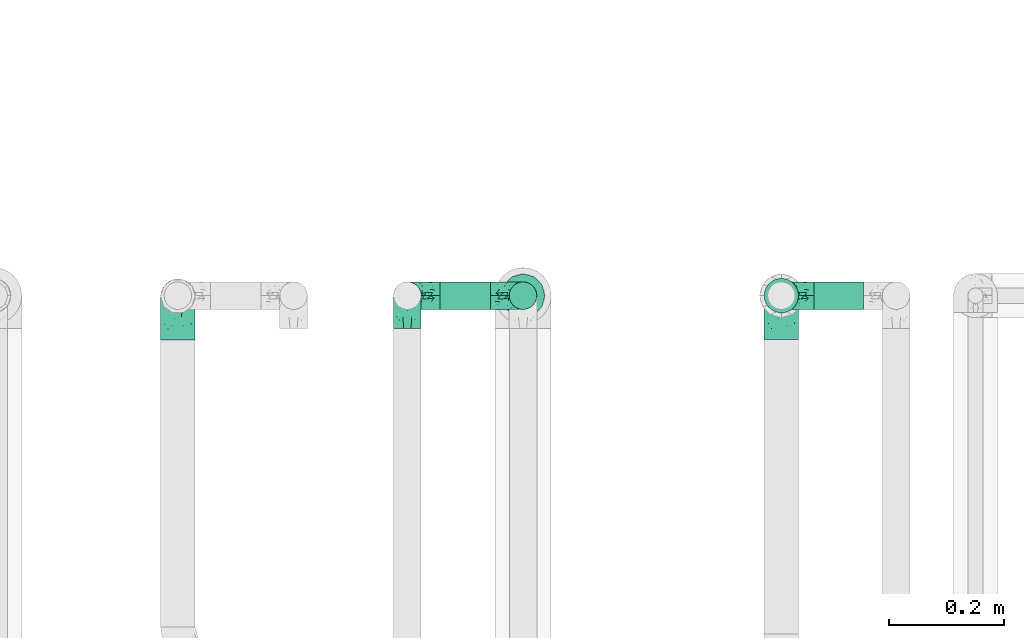
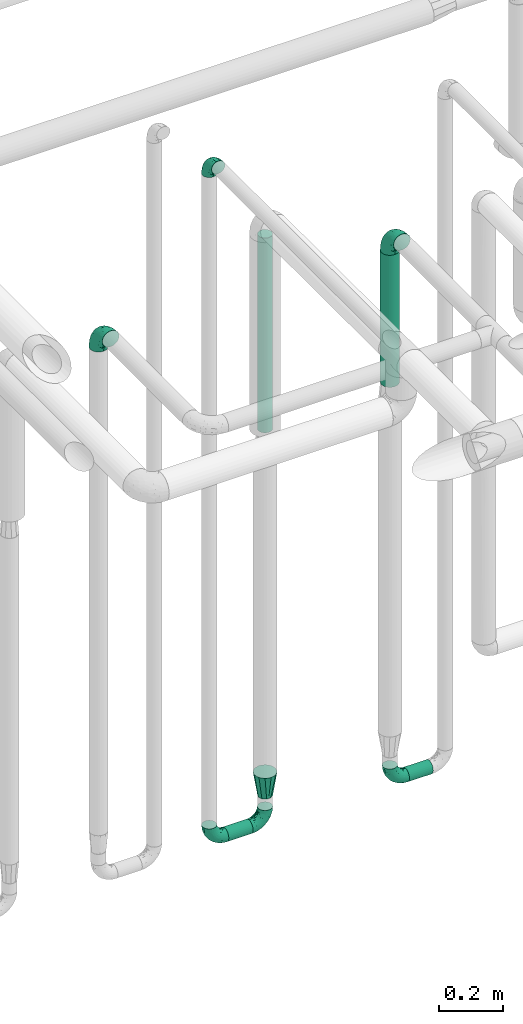
# One storey, part 698 of 827: 7 flow fittings, 4 flow segments.
"""IFC2X3 building model written with IfcOpenShell, lengths in millimetres."""

from ifc_helpers import new_model, entity, si_unit, converted_unit, derived_unit, direction, frame, origin, origin_2d_with_axis, place, context, subcontext, project, spatial, circle, extrude, faceted_brep, source, transform, mapped, material, type_object, type_shapes, element, save


model = new_model("IFC2X3")

# Units and contexts
model_context = context("Model", 3, precision=0.01, world=origin(), true_north=direction((6.12303176911189e-17, 1.0)))
body_context = subcontext(model_context, "Body", "Model", "MODEL_VIEW")
ifc_project = project(units=[si_unit("LENGTHUNIT", "METRE", prefix="MILLI"), si_unit("AREAUNIT", "SQUARE_METRE"), si_unit("VOLUMEUNIT", "CUBIC_METRE"), converted_unit("PLANEANGLEUNIT", "DEGREE", entity("IfcRatioMeasure", 0.0174532925199433), si_unit("PLANEANGLEUNIT", "RADIAN"), dimensions=[0, 0, 0, 0, 0, 0, 0]), si_unit("MASSUNIT", "GRAM", prefix="KILO"), derived_unit("MASSDENSITYUNIT", [(si_unit("MASSUNIT", "GRAM", prefix="KILO"), 1), (si_unit("LENGTHUNIT", "METRE"), -3)]), derived_unit("MOMENTOFINERTIAUNIT", [(si_unit("LENGTHUNIT", "METRE"), 4)]), si_unit("TIMEUNIT", "SECOND"), si_unit("FREQUENCYUNIT", "HERTZ"), si_unit("THERMODYNAMICTEMPERATUREUNIT", "DEGREE_CELSIUS"), derived_unit("THERMALTRANSMITTANCEUNIT", [(si_unit("MASSUNIT", "GRAM", prefix="KILO"), 1), (si_unit("THERMODYNAMICTEMPERATUREUNIT", "KELVIN"), -1), (si_unit("TIMEUNIT", "SECOND"), -3)]), derived_unit("VOLUMETRICFLOWRATEUNIT", [(si_unit("LENGTHUNIT", "METRE"), 3), (si_unit("TIMEUNIT", "SECOND"), -1)]), derived_unit("MASSFLOWRATEUNIT", [(si_unit("MASSUNIT", "GRAM", prefix="KILO"), 1), (si_unit("TIMEUNIT", "SECOND"), -1)]), derived_unit("ROTATIONALFREQUENCYUNIT", [(si_unit("TIMEUNIT", "SECOND"), -1)]), si_unit("ELECTRICCURRENTUNIT", "AMPERE"), si_unit("ELECTRICVOLTAGEUNIT", "VOLT"), si_unit("POWERUNIT", "WATT"), si_unit("FORCEUNIT", "NEWTON", prefix="KILO"), si_unit("ILLUMINANCEUNIT", "LUX"), si_unit("LUMINOUSFLUXUNIT", "LUMEN"), si_unit("LUMINOUSINTENSITYUNIT", "CANDELA"), derived_unit("USERDEFINED", [(si_unit("MASSUNIT", "GRAM", prefix="KILO"), -1), (si_unit("LENGTHUNIT", "METRE"), -2), (si_unit("TIMEUNIT", "SECOND"), 3), (si_unit("LUMINOUSFLUXUNIT", "LUMEN"), 1)]), derived_unit("LINEARVELOCITYUNIT", [(si_unit("LENGTHUNIT", "METRE"), 1), (si_unit("TIMEUNIT", "SECOND"), -1)]), si_unit("PRESSUREUNIT", "PASCAL"), derived_unit("USERDEFINED", [(si_unit("LENGTHUNIT", "METRE"), -2), (si_unit("MASSUNIT", "GRAM", prefix="KILO"), 1), (si_unit("TIMEUNIT", "SECOND"), -2)]), derived_unit("LINEARFORCEUNIT", [(si_unit("MASSUNIT", "GRAM", prefix="KILO"), 1), (si_unit("LENGTHUNIT", "METRE"), 1), (si_unit("TIMEUNIT", "SECOND"), -2), (si_unit("LENGTHUNIT", "METRE"), -1)]), derived_unit("PLANARFORCEUNIT", [(si_unit("MASSUNIT", "GRAM", prefix="KILO"), 1), (si_unit("LENGTHUNIT", "METRE"), 1), (si_unit("TIMEUNIT", "SECOND"), -2), (si_unit("LENGTHUNIT", "METRE"), -2)])], contexts=[model_context])

# Site, building, storey
site_placement = place(None, origin())
site = spatial("IfcSite", under=ifc_project, at=site_placement, CompositionType="ELEMENT")
building_placement = place(site_placement, origin())
building = spatial("IfcBuilding", under=site, at=building_placement, CompositionType="ELEMENT")
storey_placement = place(building_placement, frame((0.0, 0.0, 28200.0)))
storey = spatial("IfcBuildingStorey", under=building, at=storey_placement, Name="08", CompositionType="ELEMENT", Elevation=28200.0)

# Flow segments
pipe_segment_type = type_object("IfcPipeSegmentType", PredefinedType="NOTDEFINED")
flow_segment_1_placement = place(storey_placement, frame((53539.81, 17468.4, 1918.17)))
element("IfcFlowSegment", 1, at=flow_segment_1_placement, inside=storey, type_object=pipe_segment_type, context=body_context, shape_type="SweptSolid", body=[
    extrude(circle(Radius=30.0, at=origin_2d_with_axis()), frame((31.6, 31.6, 0.0)), (0.0, 0.0, 1.0), 504.000000000011),
])
flow_segment_2_placement = place(storey_placement, frame((52976.38, 17474.4, 374.4)))
element("IfcFlowSegment", 2, at=flow_segment_2_placement, inside=storey, type_object=pipe_segment_type, context=body_context, shape_type="SweptSolid", body=[
    extrude(circle(Radius=24.0, at=origin_2d_with_axis()), frame((0.0, 25.6, 25.6), z_axis=(1.0, 0.0, 0.0), x_axis=(0.0, 1.0, 0.0)), (0.0, 0.0, 1.0), 87.6742700000116),
])
flow_segment_3_placement = place(storey_placement, frame((53095.46, 17474.4, 1898.17)))
element("IfcFlowSegment", 3, at=flow_segment_3_placement, inside=storey, type_object=pipe_segment_type, context=body_context, shape_type="SweptSolid", body=[
    extrude(circle(Radius=24.0, at=origin_2d_with_axis()), frame((25.6, 25.6, 0.0)), (0.0, 0.0, 1.0), 743.078196918212),
])
flow_segment_4_placement = place(storey_placement, frame((53628.41, 17474.4, 374.4)))
element("IfcFlowSegment", 4, at=flow_segment_4_placement, inside=storey, type_object=pipe_segment_type, context=body_context, shape_type="SweptSolid", body=[
    extrude(circle(Radius=24.0, at=origin_2d_with_axis()), frame((0.0, 25.6, 25.6), z_axis=(1.0, 0.0, 0.0), x_axis=(0.0, 1.0, 0.0)), (0.0, 0.0, 1.0), 86.0000000000238),
])

# Flow fittings
ifc_material = material()
pipe_fitting_type_1 = type_object("IfcPipeFittingType", Name="ADSK_1", PredefinedType="NOTDEFINED", material=ifc_material)
shared_shape_1 = source(origin(), body_context, "Body", "Brep", [
    faceted_brep([(-57.0, 12.07, -20.91), (-57.0, 6.25, -23.33), (-57.0, 0.0, -24.15), (-57.0, -6.25, -23.33), (-57.0, -12.08, -20.91), (-57.0, -17.08, -17.08), (-57.0, -20.91, -12.08), (-57.0, -23.33, -6.25), (-57.0, -24.15, 0.0), (-57.0, -23.33, 6.25), (-57.0, -20.91, 12.07), (-57.0, -17.08, 17.08), (-57.0, -12.08, 20.91), (-57.0, -6.25, 23.33), (-57.0, 0.0, 24.15), (-57.0, 6.25, 23.33), (-57.0, 12.07, 20.91), (-57.0, 17.08, 17.08), (-57.0, 20.91, 12.07), (-57.0, 23.33, 6.25), (-57.0, 24.15, 0.0), (-57.0, 23.33, -6.25), (-57.0, 20.91, -12.08), (-57.0, 17.08, -17.08), (0.0, 57.0, -24.15), (-6.25, 57.0, -23.33), (-12.07, 57.0, -20.91), (-17.08, 57.0, -17.08), (-20.91, 57.0, -12.08), (-23.33, 57.0, -6.25), (-24.15, 57.0, 0.0), (-23.33, 57.0, 6.25), (-20.91, 57.0, 12.07), (-17.08, 57.0, 17.08), (-12.07, 57.0, 20.91), (-6.25, 57.0, 23.33), (0.0, 57.0, 24.15), (6.25, 57.0, 23.33), (12.08, 57.0, 20.91), (17.08, 57.0, 17.08), (20.91, 57.0, 12.07), (23.33, 57.0, 6.25), (24.15, 57.0, 0.0), (23.33, 57.0, -6.25), (20.91, 57.0, -12.08), (17.08, 57.0, -17.08), (12.08, 57.0, -20.91), (6.25, 57.0, -23.33), (14.9, 21.14, 6.17), (13.61, 24.64, 12.48), (6.23, 8.95, 8.98), (-41.47, -21.06, 0.0), (-41.92, -18.38, 13.72), (-24.64, -13.61, 12.48), (-37.37, -13.24, 18.15), (-6.8, -4.93, 8.18), (-21.76, -15.19, 6.22), (-12.78, -9.18, 0.0), (-37.73, -20.51, 7.75), (-7.38, 7.38, 20.24), (-23.37, -4.26, 20.42), (-11.9, -3.19, 15.86), (-42.14, -8.7, 21.82), (13.24, 37.37, 18.15), (9.33, 23.53, 16.85), (4.26, 23.37, 20.42), (2.77, 10.92, 15.55), (-29.46, 0.91, 23.52), (-44.13, 20.56, 15.69), (-39.25, 26.33, 10.88), (-49.02, 22.92, 9.96), (-34.58, 23.87, 17.15), (-15.8, 6.8, 22.81), (-8.67, 20.47, 23.88), (-18.12, 12.9, 24.08), (-48.29, 14.92, 19.65), (-44.06, -2.85, 23.78), (-9.23, 48.95, 22.58), (-3.78, 42.74, 24.07), (-40.34, 4.26, 24.09), (-44.02, 26.14, 5.46), (-44.04, 9.88, 22.74), (-4.95, 16.87, 22.52), (-2.75, 1.43, 12.5), (-25.48, 40.98, 10.71), (20.51, 37.73, 7.75), (18.38, 41.92, 13.72), (8.7, 42.14, 21.82), (-25.95, -17.97, 0.0), (2.85, 44.06, 23.78), (21.06, 41.47, 0.0), (17.97, 25.95, 0.0), (-24.04, -9.27, 17.13), (-33.26, 33.26, 5.86), (-28.55, 40.57, 0.0), (-40.57, 28.55, 0.0), (-25.29, 47.19, 4.06), (-27.01, 31.1, 16.77), (-15.7, 43.95, 19.9), (-20.27, 45.22, 15.61), (-30.53, 31.98, 12.64), (-11.28, 38.33, 22.92), (-9.97, 27.88, 24.09), (-20.15, 30.26, 21.25), (-31.25, 11.75, 23.64), (-28.75, 7.23, 24.15), (-29.53, 18.06, 22.27), (-28.44, 24.21, 20.02), (-37.55, 17.7, 20.26), (-15.88, 29.25, 22.99), (-20.82, 20.82, 23.44), (-0.91, 29.46, 23.52), (-13.5, -7.67, 12.04), (1.49, 1.56, 5.16), (8.86, 10.35, 4.59), (0.38, -0.38, 0.0), (9.18, 12.78, 0.0), (-37.37, -13.24, -18.15), (8.86, 10.35, -4.59), (-45.22, 20.27, -15.61), (-43.95, 15.7, -19.9), (-38.33, 11.28, -22.92), (-48.95, 9.23, -22.58), (-47.19, 25.29, -4.06), (-33.26, 33.26, -5.86), (18.38, 41.92, -13.72), (-30.26, 20.15, -21.25), (2.85, 44.06, -23.78), (-4.26, 40.34, -24.09), (-40.98, 25.48, -10.71), (-41.92, -18.38, -13.72), (9.25, 23.5, -16.92), (4.26, 23.37, -20.42), (13.24, 37.37, -18.15), (-37.73, -20.51, -7.75), (-11.75, 31.25, -23.64), (-7.23, 28.75, -24.15), (-12.9, 18.12, -24.08), (8.7, 42.14, -21.82), (-44.06, -2.85, -23.78), (-6.8, 15.8, -22.81), (-20.47, 8.67, -23.88), (-24.64, -13.61, -12.48), (-42.74, 3.78, -24.07), (-18.06, 29.53, -22.27), (-24.21, 28.44, -20.02), (-27.88, 9.97, -24.09), (-31.1, 27.01, -16.77), (-26.14, 44.02, -5.46), (14.9, 21.14, -6.17), (20.51, 37.73, -7.75), (-9.88, 44.04, -22.74), (-20.56, 44.13, -15.69), (-21.76, -15.19, -6.22), (-13.5, -7.67, -12.04), (-24.14, -9.76, -16.74), (-11.9, -3.19, -15.86), (-14.92, 48.29, -19.65), (-23.37, -4.26, -20.42), (-0.91, 29.46, -23.52), (-26.33, 39.25, -10.88), (-23.87, 34.58, -17.15), (-42.14, -8.7, -21.82), (-22.92, 49.02, -9.96), (13.61, 24.64, -12.48), (-31.98, 30.53, -12.64), (-16.87, 4.95, -22.52), (-17.7, 37.55, -20.26), (-29.25, 15.88, -22.99), (-20.82, 20.82, -23.44), (-29.46, 0.91, -23.52), (-7.38, 7.38, -20.24), (2.77, 10.92, -15.55), (6.23, 8.95, -8.98), (-6.8, -4.93, -8.18), (-2.81, 1.41, -12.54), (1.49, 1.56, -5.16)], [[[0, 1, 2, 3, 4, 5, 6, 7, 8, 9, 10, 11, 12, 13, 14, 15, 16, 17, 18, 19, 20, 21, 22, 23]], [[24, 25, 26, 27, 28, 29, 30, 31, 32, 33, 34, 35, 36, 37, 38, 39, 40, 41, 42, 43, 44, 45, 46, 47]], [[48, 49, 50]], [[9, 8, 51]], [[52, 53, 54]], [[55, 56, 57]], [[10, 58, 52]], [[9, 58, 10]], [[59, 60, 61]], [[54, 12, 11]], [[54, 62, 12]], [[63, 39, 38]], [[64, 65, 66]], [[62, 60, 67]], [[68, 69, 70]], [[71, 69, 68]], [[72, 73, 74]], [[16, 75, 17]], [[13, 76, 14]], [[35, 77, 78]], [[14, 79, 15]], [[17, 68, 18]], [[14, 76, 79]], [[20, 19, 80]], [[70, 19, 18]], [[81, 15, 79]], [[15, 81, 16]], [[73, 72, 82]], [[66, 83, 50]], [[32, 31, 84]], [[85, 86, 49]], [[63, 87, 65]], [[56, 58, 88]], [[36, 89, 37]], [[85, 41, 40]], [[36, 35, 78]], [[90, 41, 85]], [[40, 39, 86]], [[12, 62, 13]], [[86, 85, 40]], [[48, 85, 49]], [[85, 91, 90]], [[87, 38, 37]], [[92, 60, 54]], [[80, 69, 93]], [[93, 94, 95]], [[10, 52, 11]], [[94, 96, 30]], [[97, 98, 99]], [[80, 93, 95]], [[100, 97, 84]], [[99, 98, 33]], [[101, 102, 78]], [[103, 101, 98]], [[96, 31, 30]], [[77, 98, 101]], [[77, 35, 34]], [[34, 33, 98]], [[9, 51, 58]], [[87, 63, 38]], [[104, 105, 74]], [[106, 103, 107]], [[106, 81, 104]], [[75, 68, 17]], [[108, 107, 71]], [[33, 32, 99]], [[109, 103, 110]], [[101, 109, 102]], [[89, 78, 111]], [[53, 52, 58]], [[54, 11, 52]], [[60, 62, 54]], [[88, 58, 51]], [[76, 62, 67]], [[53, 112, 92]], [[60, 59, 72]], [[39, 63, 86]], [[49, 86, 63]], [[89, 87, 37]], [[42, 41, 90]], [[111, 82, 65]], [[111, 65, 87]], [[65, 59, 66]], [[104, 81, 79]], [[75, 81, 108]], [[32, 84, 99]], [[97, 99, 84]], [[98, 97, 103]], [[106, 107, 108]], [[74, 102, 110]], [[111, 78, 102]], [[74, 110, 104]], [[74, 67, 72]], [[61, 92, 112]], [[66, 59, 61]], [[56, 53, 58]], [[66, 50, 49]], [[61, 112, 83]], [[66, 49, 64]], [[78, 89, 36]], [[87, 89, 111]], [[62, 76, 13]], [[79, 76, 67]], [[100, 93, 69]], [[96, 93, 84]], [[55, 113, 50]], [[113, 114, 50]], [[104, 79, 105]], [[106, 104, 110]], [[20, 80, 95]], [[85, 48, 91]], [[115, 114, 113]], [[116, 91, 48]], [[70, 80, 19]], [[93, 96, 94]], [[84, 31, 96]], [[103, 106, 110]], [[81, 106, 108]], [[103, 97, 107]], [[71, 107, 97]], [[71, 97, 100]], [[108, 71, 68]], [[79, 67, 105]], [[67, 74, 105]], [[115, 113, 57]], [[112, 56, 55]], [[56, 88, 57]], [[60, 72, 67]], [[82, 72, 59]], [[65, 82, 59]], [[82, 111, 73]], [[111, 102, 73]], [[102, 74, 73]], [[81, 75, 16]], [[68, 75, 108]], [[68, 70, 18]], [[80, 70, 69]], [[98, 77, 34]], [[78, 77, 101]], [[93, 100, 84]], [[71, 100, 69]], [[102, 109, 110]], [[101, 103, 109]], [[53, 92, 54]], [[61, 60, 92]], [[56, 112, 53]], [[83, 112, 55]], [[50, 83, 55]], [[61, 83, 66]], [[49, 63, 64]], [[65, 64, 63]], [[57, 113, 55]], [[114, 115, 116]], [[116, 48, 114]], [[48, 50, 114]], [[117, 5, 4]], [[116, 115, 118]], [[119, 120, 23]], [[121, 122, 120]], [[95, 123, 20]], [[0, 23, 120]], [[124, 95, 94]], [[125, 45, 44]], [[121, 120, 126]], [[24, 127, 128]], [[22, 21, 129]], [[0, 122, 1]], [[5, 117, 130]], [[131, 132, 133]], [[134, 88, 51]], [[135, 136, 137]], [[6, 5, 130]], [[46, 138, 47]], [[139, 3, 2]], [[140, 141, 137]], [[6, 134, 7]], [[134, 130, 142]], [[143, 2, 1]], [[144, 126, 145]], [[121, 146, 143]], [[147, 120, 119]], [[94, 148, 124]], [[149, 150, 91]], [[30, 29, 148]], [[151, 25, 128]], [[27, 152, 28]], [[134, 153, 88]], [[154, 155, 156]], [[27, 26, 157]], [[151, 26, 25]], [[155, 158, 156]], [[24, 47, 127]], [[1, 122, 143]], [[138, 132, 159]], [[160, 152, 161]], [[24, 128, 25]], [[46, 133, 138]], [[162, 117, 4]], [[148, 160, 124]], [[152, 160, 163]], [[154, 142, 155]], [[45, 125, 133]], [[133, 46, 45]], [[125, 164, 133]], [[51, 7, 134]], [[42, 90, 43]], [[165, 147, 129]], [[153, 134, 142]], [[43, 150, 44]], [[162, 4, 3]], [[141, 140, 166]], [[117, 162, 158]], [[163, 29, 28]], [[43, 90, 150]], [[123, 21, 20]], [[144, 151, 135]], [[157, 152, 27]], [[167, 145, 161]], [[23, 22, 119]], [[168, 126, 169]], [[121, 168, 146]], [[139, 143, 170]], [[142, 130, 117]], [[8, 7, 51]], [[134, 6, 130]], [[139, 162, 3]], [[170, 166, 158]], [[170, 158, 162]], [[158, 171, 156]], [[44, 150, 125]], [[91, 150, 90]], [[164, 125, 150]], [[132, 138, 133]], [[127, 138, 159]], [[131, 164, 172]], [[132, 171, 140]], [[135, 151, 128]], [[157, 151, 167]], [[22, 129, 119]], [[147, 119, 129]], [[120, 147, 126]], [[144, 145, 167]], [[137, 146, 169]], [[170, 143, 146]], [[137, 169, 135]], [[137, 159, 140]], [[171, 172, 156]], [[173, 174, 175]], [[156, 175, 154]], [[174, 57, 153]], [[132, 172, 171]], [[172, 164, 173]], [[143, 139, 2]], [[162, 139, 170]], [[138, 127, 47]], [[128, 127, 159]], [[165, 124, 160]], [[123, 124, 129]], [[149, 173, 164]], [[176, 174, 173]], [[135, 128, 136]], [[144, 135, 169]], [[150, 149, 164]], [[176, 118, 115]], [[149, 91, 116]], [[30, 148, 94]], [[163, 148, 29]], [[124, 123, 95]], [[129, 21, 123]], [[126, 144, 169]], [[151, 144, 167]], [[126, 147, 145]], [[161, 145, 147]], [[161, 147, 165]], [[167, 161, 152]], [[128, 159, 136]], [[159, 137, 136]], [[154, 153, 142]], [[132, 140, 159]], [[174, 176, 57]], [[57, 88, 153]], [[166, 140, 171]], [[158, 166, 171]], [[166, 170, 141]], [[170, 146, 141]], [[146, 137, 141]], [[151, 157, 26]], [[152, 157, 167]], [[152, 163, 28]], [[148, 163, 160]], [[120, 122, 0]], [[143, 122, 121]], [[124, 165, 129]], [[161, 165, 160]], [[146, 168, 169]], [[121, 126, 168]], [[142, 117, 155]], [[158, 155, 117]], [[175, 156, 172]], [[153, 154, 174]], [[173, 175, 172]], [[174, 154, 175]], [[164, 131, 133]], [[172, 132, 131]], [[176, 173, 118]], [[57, 176, 115]], [[173, 149, 118]], [[149, 116, 118]]]),
])
type_shapes(pipe_fitting_type_1, [shared_shape_1])
for number, where, z_axis, x_axis, name in (
    (5, (53121.06, 17500.0, 400.0), (0.0, 1.0, 0.0), (0.0, 0.0, -1.0), "ADSK_1"),
    (6, (52919.38, 17500.0, 400.0), (0.0, 1.0, 0.0), (-1.0, 0.0, 0.0), "ADSK_1"),
    (7, (52919.38, 17500.0, 3000.0), (1.0, 0.0, 0.0), (0.0, 0.0, 1.0), "ADSK_1"),
    (8, (53571.41, 17500.0, 400.0), (0.0, 1.0, 0.0), (-1.0, 0.0, 0.0), "ADSK_1"),
):
    element("IfcFlowFitting", number, at=place(storey_placement, frame(where, z_axis=z_axis, x_axis=x_axis)), inside=storey, type_object=pipe_fitting_type_1, material=ifc_material, Name=name, ObjectType="ADSK_1", context=body_context, shape_type="MappedRepresentation", body=[
        mapped(shared_shape_1, transform((0.0, 0.0, 0.0), scale=1.0)),
    ])
pipe_fitting_type_2 = type_object("IfcPipeFittingType", Name="ADSK_1", PredefinedType="NOTDEFINED", material=ifc_material)
shared_shape_2 = source(origin(), body_context, "Body", "Brep", [
    faceted_brep([(-76.0, 15.07, -26.11), (-76.0, 7.8, -29.12), (-76.0, 0.0, -30.15), (-76.0, -7.8, -29.12), (-76.0, -15.08, -26.11), (-76.0, -21.32, -21.32), (-76.0, -26.11, -15.08), (-76.0, -29.12, -7.8), (-76.0, -30.15, 0.0), (-76.0, -29.12, 7.8), (-76.0, -26.11, 15.07), (-76.0, -21.32, 21.32), (-76.0, -15.08, 26.11), (-76.0, -7.8, 29.12), (-76.0, 0.0, 30.15), (-76.0, 7.8, 29.12), (-76.0, 15.07, 26.11), (-76.0, 21.32, 21.32), (-76.0, 26.11, 15.07), (-76.0, 29.12, 7.8), (-76.0, 30.15, 0.0), (-76.0, 29.12, -7.8), (-76.0, 26.11, -15.08), (-76.0, 21.32, -21.32), (0.0, 76.0, -30.15), (-7.8, 76.0, -29.12), (-15.07, 76.0, -26.11), (-21.32, 76.0, -21.32), (-26.11, 76.0, -15.08), (-29.12, 76.0, -7.8), (-30.15, 76.0, 0.0), (-29.12, 76.0, 7.8), (-26.11, 76.0, 15.07), (-21.32, 76.0, 21.32), (-15.07, 76.0, 26.11), (-7.8, 76.0, 29.12), (0.0, 76.0, 30.15), (7.8, 76.0, 29.12), (15.08, 76.0, 26.11), (21.32, 76.0, 21.32), (26.11, 76.0, 15.07), (29.12, 76.0, 7.8), (30.15, 76.0, 0.0), (29.12, 76.0, -7.8), (26.11, 76.0, -15.08), (21.32, 76.0, -21.32), (15.08, 76.0, -26.11), (7.8, 76.0, -29.12), (10.79, 31.43, 21.07), (4.32, 31.7, 25.72), (1.65, 15.19, 19.92), (-61.17, -27.8, 0.0), (-51.1, -25.49, 9.84), (-56.14, -10.61, 27.27), (-31.7, -4.32, 25.72), (-39.75, 1.72, 29.41), (-43.2, -24.95, 0.0), (-1.86, 1.86, 0.0), (4.49, 7.65, 5.78), (-7.82, -4.61, 5.83), (-56.21, -22.79, 17.21), (-58.98, -3.38, 29.7), (-53.96, 5.6, 30.07), (-10.86, 10.86, 25.48), (-17.2, -2.6, 20.44), (-49.15, -16.01, 22.7), (-22.18, -14.24, 7.99), (-28.4, -17.42, 0.0), (-13.61, -9.88, 0.0), (-39.0, 23.48, 27.76), (-58.76, 12.54, 28.36), (-41.61, 15.41, 29.48), (16.01, 49.15, 22.7), (-58.55, 25.93, 19.53), (-51.53, 33.5, 13.51), (-64.92, 28.76, 12.4), (-7.48, 23.14, 28.25), (-1.72, 39.75, 29.41), (-12.04, 27.88, 29.88), (-63.91, 18.81, 24.52), (-11.63, 65.16, 28.18), (-4.97, 57.02, 30.05), (9.88, 13.61, 0.0), (-62.5, 31.74, 5.02), (-45.17, 30.98, 21.2), (-21.78, 9.76, 28.58), (10.61, 56.14, 27.27), (-32.09, 54.42, 13.26), (22.79, 56.21, 17.21), (15.38, 31.17, 15.63), (25.49, 51.1, 9.84), (21.84, 36.35, 5.92), (24.95, 43.2, 0.0), (3.38, 58.98, 29.7), (-31.17, -15.38, 15.63), (-39.39, 41.78, 15.45), (-34.56, 41.13, 20.79), (-39.81, -23.25, 5.49), (27.8, 61.17, 0.0), (-31.74, 62.5, 5.02), (-53.07, 36.29, 0.0), (-42.95, 42.95, 7.29), (-36.29, 53.07, 0.0), (-19.83, 58.51, 24.79), (-25.48, 60.2, 19.41), (-14.53, 50.96, 28.57), (-13.31, 37.09, 30.07), (-26.16, 40.06, 26.4), (-32.43, -10.35, 21.9), (17.42, 28.4, 0.0), (14.24, 22.18, 7.99), (-38.67, 9.72, 30.15), (-24.66, 17.36, 30.09), (-37.08, 31.49, 24.99), (-49.27, 22.83, 25.24), (-20.8, 38.81, 28.63), (-27.58, 27.58, 29.2), (-36.07, -20.23, 10.71), (-15.19, -6.16, 14.9), (6.6, 15.4, 14.49), (-2.51, 2.51, 11.35), (-65.16, 11.63, -28.18), (-49.15, -16.01, -22.7), (-57.02, 4.97, -30.05), (-25.93, 58.55, -19.53), (-33.5, 51.53, -13.51), (-28.76, 64.92, -12.4), (-60.2, 25.48, -19.41), (-58.51, 19.83, -24.79), (4.61, 7.82, -5.83), (-7.65, -4.49, -5.78), (-2.51, 2.51, -11.35), (-62.5, 31.74, -5.02), (-50.96, 14.53, -28.57), (-37.09, 13.31, -30.07), (-42.95, 42.95, -7.29), (25.49, 51.1, -9.84), (22.79, 56.21, -17.21), (-40.06, 26.16, -26.4), (3.38, 58.98, -29.7), (-5.6, 53.96, -30.07), (-27.88, 12.04, -29.88), (-9.76, 21.78, -28.58), (-23.14, 7.48, -28.25), (-51.1, -25.49, -9.84), (15.38, 31.17, -15.63), (16.01, 49.15, -22.7), (-23.48, 39.0, -27.76), (-12.54, 58.76, -28.36), (-15.41, 41.61, -29.48), (-56.21, -22.79, -17.21), (-9.72, 38.67, -30.15), (-17.36, 24.66, -30.09), (-22.18, -14.24, -7.99), (-41.13, 34.56, -20.79), (-31.74, 62.5, -5.02), (-58.98, -3.38, -29.7), (-31.17, -15.38, -15.63), (-56.14, -10.61, -27.27), (14.24, 22.18, -7.99), (23.25, 39.81, -5.49), (-31.49, 37.08, -24.99), (-15.19, -6.16, -14.9), (1.65, 15.19, -19.92), (-18.81, 63.91, -24.52), (-32.59, -11.62, -20.84), (-31.7, -4.32, -25.72), (-17.2, -2.6, -20.44), (-39.75, 1.72, -29.41), (-54.42, 32.09, -13.26), (-30.98, 45.17, -21.2), (10.61, 56.14, -27.27), (10.23, 31.31, -21.52), (4.32, 31.7, -25.72), (-41.78, 39.39, -15.45), (-1.72, 39.75, -29.41), (-36.35, -21.84, -5.92), (-22.83, 49.27, -25.24), (-38.81, 20.8, -28.63), (-27.58, 27.58, -29.2), (-10.86, 10.86, -25.48), (20.23, 36.07, -10.71), (6.6, 15.4, -14.49)], [[[0, 1, 2, 3, 4, 5, 6, 7, 8, 9, 10, 11, 12, 13, 14, 15, 16, 17, 18, 19, 20, 21, 22, 23]], [[24, 25, 26, 27, 28, 29, 30, 31, 32, 33, 34, 35, 36, 37, 38, 39, 40, 41, 42, 43, 44, 45, 46, 47]], [[48, 49, 50]], [[51, 52, 9]], [[53, 54, 55]], [[9, 52, 10]], [[56, 52, 51]], [[57, 58, 59]], [[11, 10, 60]], [[14, 61, 62]], [[63, 54, 64]], [[65, 12, 11]], [[65, 53, 12]], [[66, 67, 68]], [[69, 70, 71]], [[72, 39, 38]], [[73, 74, 75]], [[15, 70, 16]], [[76, 77, 78]], [[16, 79, 17]], [[13, 61, 14]], [[35, 80, 81]], [[14, 62, 15]], [[17, 73, 18]], [[57, 82, 58]], [[20, 19, 83]], [[75, 19, 18]], [[70, 15, 62]], [[73, 84, 74]], [[78, 85, 76]], [[38, 86, 72]], [[32, 31, 87]], [[88, 89, 90]], [[91, 92, 90]], [[72, 86, 49]], [[36, 93, 37]], [[75, 83, 19]], [[36, 35, 81]], [[60, 94, 65]], [[40, 90, 41]], [[95, 96, 87]], [[88, 90, 40]], [[66, 97, 67]], [[90, 98, 41]], [[40, 39, 88]], [[99, 31, 30]], [[20, 83, 100]], [[101, 102, 100]], [[52, 60, 10]], [[102, 99, 30]], [[96, 103, 104]], [[83, 101, 100]], [[12, 53, 13]], [[104, 103, 33]], [[105, 106, 81]], [[107, 105, 103]], [[64, 54, 108]], [[80, 103, 105]], [[80, 35, 34]], [[34, 33, 103]], [[86, 38, 37]], [[109, 110, 82]], [[71, 111, 112]], [[69, 107, 113]], [[79, 73, 17]], [[114, 113, 84]], [[33, 32, 104]], [[115, 107, 116]], [[105, 115, 106]], [[93, 81, 77]], [[54, 53, 65]], [[61, 53, 55]], [[108, 94, 64]], [[54, 63, 85]], [[93, 86, 37]], [[77, 76, 49]], [[77, 49, 86]], [[49, 63, 50]], [[60, 52, 117]], [[65, 11, 60]], [[39, 72, 88]], [[89, 88, 72]], [[71, 70, 62]], [[79, 70, 114]], [[103, 96, 107]], [[69, 113, 114]], [[112, 106, 116]], [[77, 81, 106]], [[112, 116, 71]], [[112, 55, 85]], [[64, 50, 63]], [[57, 59, 68]], [[32, 87, 104]], [[96, 104, 87]], [[94, 118, 64]], [[50, 119, 89]], [[50, 64, 118]], [[50, 89, 48]], [[81, 93, 36]], [[86, 93, 77]], [[53, 61, 13]], [[62, 61, 55]], [[71, 62, 111]], [[69, 71, 116]], [[95, 101, 74]], [[99, 101, 87]], [[118, 66, 59]], [[117, 97, 66]], [[117, 66, 94]], [[91, 89, 110]], [[91, 110, 109]], [[110, 89, 119]], [[9, 8, 51]], [[98, 90, 92]], [[98, 42, 41]], [[101, 83, 74]], [[101, 99, 102]], [[87, 31, 99]], [[62, 55, 111]], [[55, 112, 111]], [[107, 69, 116]], [[70, 69, 114]], [[107, 96, 113]], [[84, 113, 96]], [[84, 96, 95]], [[114, 84, 73]], [[70, 79, 16]], [[73, 79, 114]], [[54, 85, 55]], [[76, 85, 63]], [[49, 76, 63]], [[77, 106, 78]], [[106, 112, 78]], [[85, 78, 112]], [[73, 75, 18]], [[83, 75, 74]], [[103, 80, 34]], [[81, 80, 105]], [[101, 95, 87]], [[84, 95, 74]], [[106, 115, 116]], [[105, 107, 115]], [[120, 59, 58]], [[82, 110, 58]], [[119, 58, 110]], [[118, 59, 120]], [[66, 68, 59]], [[54, 65, 108]], [[94, 108, 65]], [[66, 118, 94]], [[50, 118, 120]], [[50, 120, 119]], [[119, 120, 58]], [[89, 72, 48]], [[49, 48, 72]], [[60, 117, 94]], [[117, 52, 97]], [[52, 56, 97]], [[67, 97, 56]], [[92, 91, 109]], [[89, 91, 90]], [[121, 1, 0]], [[122, 5, 4]], [[2, 1, 123]], [[124, 125, 126]], [[127, 128, 23]], [[129, 130, 131]], [[100, 132, 20]], [[133, 134, 123]], [[135, 100, 102]], [[136, 137, 44]], [[133, 128, 138]], [[24, 139, 140]], [[141, 142, 143]], [[121, 128, 133]], [[6, 144, 7]], [[137, 145, 146]], [[144, 51, 7]], [[147, 148, 149]], [[144, 6, 150]], [[149, 151, 152]], [[153, 68, 67]], [[154, 128, 127]], [[30, 155, 102]], [[43, 42, 98]], [[156, 3, 2]], [[157, 144, 150]], [[158, 4, 3]], [[24, 140, 25]], [[155, 135, 102]], [[159, 160, 109]], [[30, 29, 155]], [[147, 138, 161]], [[27, 124, 28]], [[57, 129, 82]], [[162, 163, 131]], [[27, 26, 164]], [[148, 26, 25]], [[165, 166, 167]], [[24, 47, 139]], [[143, 168, 141]], [[22, 21, 169]], [[125, 124, 170]], [[148, 25, 140]], [[46, 146, 171]], [[158, 122, 4]], [[0, 23, 128]], [[1, 121, 123]], [[109, 82, 159]], [[45, 44, 137]], [[146, 46, 45]], [[136, 43, 98]], [[132, 21, 20]], [[136, 98, 92]], [[172, 173, 146]], [[46, 171, 47]], [[43, 136, 44]], [[174, 154, 169]], [[171, 173, 175]], [[6, 5, 150]], [[126, 29, 28]], [[176, 56, 144]], [[122, 158, 166]], [[164, 124, 27]], [[177, 161, 170]], [[23, 22, 127]], [[178, 138, 179]], [[133, 178, 134]], [[156, 123, 168]], [[156, 158, 3]], [[168, 143, 166]], [[168, 166, 158]], [[166, 180, 167]], [[173, 171, 146]], [[139, 171, 175]], [[172, 145, 163]], [[173, 180, 142]], [[5, 122, 150]], [[157, 150, 122]], [[137, 136, 181]], [[146, 45, 137]], [[149, 148, 140]], [[164, 148, 177]], [[128, 154, 138]], [[147, 161, 177]], [[152, 134, 179]], [[168, 123, 134]], [[152, 179, 149]], [[152, 175, 142]], [[57, 130, 129]], [[157, 165, 167]], [[22, 169, 127]], [[154, 127, 169]], [[163, 167, 180]], [[162, 157, 167]], [[173, 163, 180]], [[182, 163, 145]], [[123, 156, 2]], [[158, 156, 168]], [[171, 139, 47]], [[140, 139, 175]], [[149, 140, 151]], [[147, 149, 179]], [[174, 135, 125]], [[132, 135, 169]], [[176, 157, 153]], [[176, 153, 67]], [[153, 157, 162]], [[182, 159, 129]], [[181, 160, 159]], [[181, 159, 145]], [[51, 144, 56]], [[51, 8, 7]], [[135, 132, 100]], [[169, 21, 132]], [[126, 155, 29]], [[135, 155, 125]], [[140, 175, 151]], [[175, 152, 151]], [[138, 147, 179]], [[148, 147, 177]], [[138, 154, 161]], [[170, 161, 154]], [[170, 154, 174]], [[177, 170, 124]], [[148, 164, 26]], [[124, 164, 177]], [[173, 142, 175]], [[143, 142, 180]], [[166, 143, 180]], [[168, 134, 141]], [[134, 152, 141]], [[142, 141, 152]], [[124, 126, 28]], [[155, 126, 125]], [[128, 121, 0]], [[123, 121, 133]], [[135, 174, 169]], [[170, 174, 125]], [[134, 178, 179]], [[133, 138, 178]], [[130, 153, 162]], [[68, 153, 130]], [[57, 68, 130]], [[182, 129, 131]], [[159, 82, 129]], [[157, 122, 165]], [[166, 165, 122]], [[163, 162, 167]], [[162, 131, 130]], [[145, 172, 146]], [[163, 173, 172]], [[159, 182, 145]], [[131, 163, 182]], [[56, 176, 67]], [[157, 176, 144]], [[137, 181, 145]], [[181, 136, 160]], [[136, 92, 160]], [[109, 160, 92]]]),
])
type_shapes(pipe_fitting_type_2, [shared_shape_2])
for number, where, z_axis, x_axis, name in (
    (9, (53571.41, 17500.0, 2498.17), (-1.0, 0.0, 0.0), (0.0, 1.0, 0.0), "ADSK_1"),
    (10, (52519.38, 17499.03, 2498.17), (-1.0, 0.0, 0.0), (0.0, 1.0, 0.0), "ADSK_1"),
):
    element("IfcFlowFitting", number, at=place(storey_placement, frame(where, z_axis=z_axis, x_axis=x_axis)), inside=storey, type_object=pipe_fitting_type_2, material=ifc_material, Name=name, ObjectType="ADSK_1", context=body_context, shape_type="MappedRepresentation", body=[
        mapped(shared_shape_2, transform((0.0, 0.0, 0.0), scale=1.0)),
    ])
pipe_fitting_type_3 = type_object("IfcPipeFittingType", Name="ADSK_1", PredefinedType="NOTDEFINED", material=ifc_material)
shared_shape_3 = source(origin(), body_context, "Body", "Brep", [
    faceted_brep([(89.0, -38.05, 0.0), (89.0, -36.21, -6.85), (89.0, -32.95, -19.02), (89.0, -25.99, -25.99), (89.0, -19.03, -32.95), (89.0, -9.51, -35.5), (89.0, 0.0, -38.05), (89.0, 9.51, -35.5), (89.0, 19.02, -32.95), (89.0, 25.99, -25.99), (89.0, 32.95, -19.02), (89.0, 36.21, -6.85), (89.0, 38.05, 0.0), (89.0, 36.21, 6.85), (89.0, 32.95, 19.03), (89.0, 25.99, 25.99), (89.0, 19.02, 32.95), (89.0, 9.51, 35.5), (89.0, 0.0, 38.05), (89.0, -9.51, 35.5), (89.0, -19.03, 32.95), (89.0, -25.99, 25.99), (89.0, -32.95, 19.03), (89.0, -36.21, 6.85), (0.0, 24.15, 0.0), (0.0, 21.84, -7.1), (0.0, 19.54, -14.2), (0.0, 13.5, -18.58), (0.0, 7.46, -22.97), (0.0, 0.0, -22.97), (0.0, -7.46, -22.97), (0.0, -13.5, -18.58), (0.0, -19.54, -14.2), (0.0, -21.84, -7.1), (0.0, -24.15, 0.0), (0.0, -21.84, 7.1), (0.0, -19.54, 14.2), (0.0, -13.5, 18.58), (0.0, -7.46, 22.97), (0.0, 0.0, 22.97), (0.0, 7.46, 22.97), (0.0, 13.5, 18.58), (0.0, 19.54, 14.2), (0.0, 21.84, 7.1)], [[[0, 1, 2, 3, 4, 5, 6, 7, 8, 9, 10, 11, 12, 13, 14, 15, 16, 17, 18, 19, 20, 21, 22, 23]], [[24, 25, 26, 27, 28, 29, 30, 31, 32, 33, 34, 35, 36, 37, 38, 39, 40, 41, 42, 43]], [[2, 33, 32]], [[28, 7, 29]], [[29, 5, 30]], [[24, 12, 11]], [[3, 32, 31]], [[34, 1, 0]], [[1, 34, 33]], [[8, 28, 27]], [[2, 1, 33]], [[31, 4, 3]], [[2, 32, 3]], [[11, 25, 24]], [[26, 10, 9]], [[10, 25, 11]], [[28, 8, 7]], [[27, 26, 9]], [[26, 25, 10]], [[31, 30, 4]], [[8, 27, 9]], [[29, 7, 6]], [[5, 29, 6]], [[5, 4, 30]], [[14, 43, 42]], [[38, 19, 39]], [[39, 17, 40]], [[34, 0, 23]], [[15, 42, 41]], [[24, 13, 12]], [[13, 24, 43]], [[20, 38, 37]], [[14, 13, 43]], [[41, 16, 15]], [[14, 42, 15]], [[23, 35, 34]], [[36, 22, 21]], [[22, 35, 23]], [[38, 20, 19]], [[37, 36, 21]], [[36, 35, 22]], [[41, 40, 16]], [[20, 37, 21]], [[39, 19, 18]], [[17, 39, 18]], [[17, 16, 40]]]),
])
type_shapes(pipe_fitting_type_3, [shared_shape_3])
flow_fitting_placement = place(storey_placement, frame((53121.06, 17500.0, 500.0), z_axis=(0.0, 1.0, 0.0), x_axis=(0.0, 0.0, 1.0)))
element("IfcFlowFitting", 11, at=flow_fitting_placement, inside=storey, type_object=pipe_fitting_type_3, material=ifc_material, Name="ADSK_1", ObjectType="ADSK_1", context=body_context, shape_type="MappedRepresentation", body=[
    mapped(shared_shape_3, transform((0.0, 0.0, 0.0), scale=1.0)),
])

save(model, "model.ifc")
